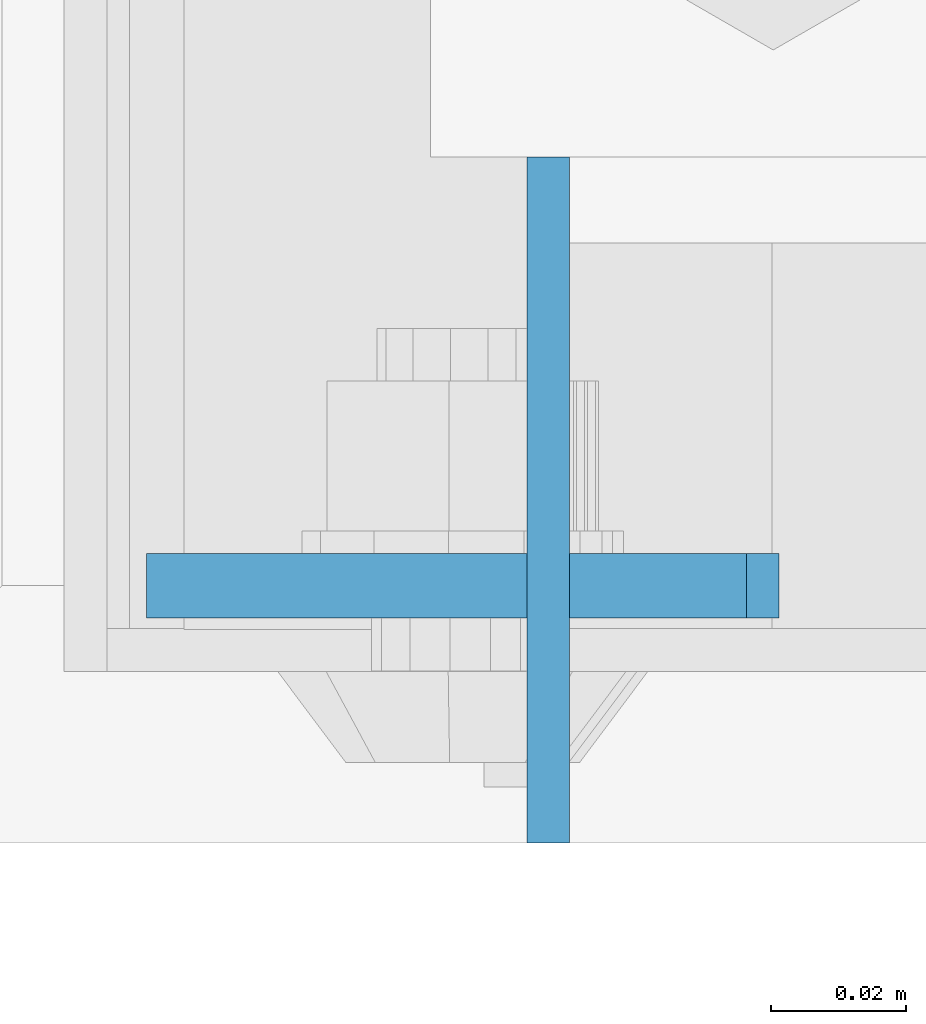
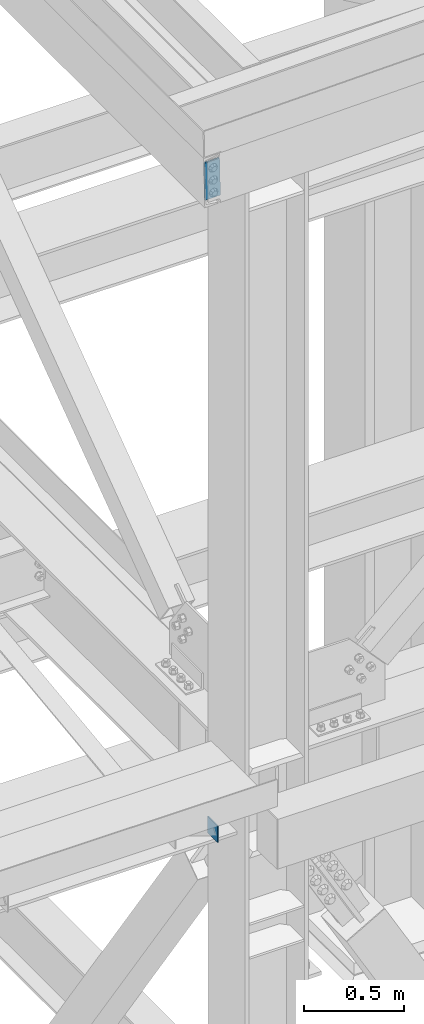
# One storey, part 3091 of 3843: 2 plates, 2 elements without a shape of their own.
"""IFC2X3 building model written with IfcOpenShell, lengths in millimetres."""

from ifc_helpers import new_model, si_unit, frame, origin_with_axes, place, context, subcontext, project, spatial, faceted_brep, material, type_object, element, aggregate, save


model = new_model("IFC2X3")

# Units and contexts
model_context = context("Model", 3, precision=1e-05, world=origin_with_axes())
body_context = subcontext(model_context, "Body", "Model", "MODEL_VIEW")
ifc_project = project(units=[si_unit("LENGTHUNIT", "METRE", prefix="MILLI"), si_unit("AREAUNIT", "SQUARE_METRE"), si_unit("VOLUMEUNIT", "CUBIC_METRE"), si_unit("MASSUNIT", "GRAM", prefix="KILO"), si_unit("TIMEUNIT", "SECOND"), si_unit("PLANEANGLEUNIT", "RADIAN"), si_unit("SOLIDANGLEUNIT", "STERADIAN"), si_unit("THERMODYNAMICTEMPERATUREUNIT", "DEGREE_CELSIUS"), si_unit("LUMINOUSINTENSITYUNIT", "LUMEN")], contexts=[model_context])

# Site, building, storey
site_placement = place(None, origin_with_axes())
site = spatial("IfcSite", under=ifc_project, at=site_placement, CompositionType="ELEMENT")
building_placement = place(site_placement, origin_with_axes())
building = spatial("IfcBuilding", under=site, at=building_placement, Name="Undefined", CompositionType="ELEMENT")
storey_placement = place(building_placement, origin_with_axes())
storey = spatial("IfcBuildingStorey", under=building, at=storey_placement, Name="Undefined", CompositionType="ELEMENT", Elevation=0.0)

# Assembly, plate
assembly_1_placement = place(storey_placement, origin_with_axes())
assembly_1 = element("IfcElementAssembly", 1, at=assembly_1_placement, inside=storey, Name="CHANNEL", AssemblyPlace="NOTDEFINED", PredefinedType="RIGID_FRAME")
ifc_material = material(Name="STEEL/A572-50")
plate_type_1 = type_object("IfcPlateType", PredefinedType="NOTDEFINED")
plate_1_placement = place(assembly_1_placement, frame((76411.9416190508, 14503.4, 46534.288407765), z_axis=(0.999776270257024, 0.0, 0.0211520550054619), x_axis=(0.0211520550054438, 0.0, -0.999776270257025)))
plate_1 = element("IfcPlate", 2, at=plate_1_placement, type_object=plate_type_1, material=ifc_material, Name="PLATE", context=body_context, shape_type="Brep", body=[
    faceted_brep([(0.0, -4.76249999999709, 0.0), (0.0, -4.76249999999709, 88.9000015258789), (0.0, 4.76249999999709, 88.9000015258789), (0.0, 4.76249999999709, 0.0), (228.600006102781, -4.7625000004191, 88.9000015257589), (228.600006102781, 4.76249999954598, 88.9000015257443), (228.600006103079, -4.7625000004482, 7.27595761418343e-12), (228.600006103079, 4.76249999954598, -7.27595761418343e-12)], [[[0, 1, 2, 3]], [[1, 4, 5, 2]], [[4, 6, 7, 5]], [[6, 0, 3, 7]], [[5, 7, 3, 2]], [[6, 4, 1, 0]]]),
])
aggregate(assembly_1, [plate_1])

assembly_2_placement = place(storey_placement, origin_with_axes())
assembly_2 = element("IfcElementAssembly", 3, at=assembly_2_placement, inside=storey, Name="BEAM", AssemblyPlace="NOTDEFINED", PredefinedType="RIGID_FRAME")
plate_type_2 = type_object("IfcPlateType", PredefinedType="NOTDEFINED")
plate_2_placement = place(assembly_2_placement, frame((76471.4625, 14566.8999999151, 42468.7999999095), z_axis=(0.0, 0.0, -1.0), x_axis=(0.0, -1.0, 0.0)))
plate_2 = element("IfcPlate", 4, at=plate_2_placement, type_object=plate_type_2, material=ifc_material, Name="PLATE", context=body_context, shape_type="Brep", body=[
    faceted_brep([(0.0, -3.17499999999927, 0.0), (0.0, -3.17499999999927, 101.600000000006), (0.0, 3.17499999999927, 101.600000000006), (0.0, 3.17499999999927, 0.0), (101.6, -3.17500000000291, 101.599999999999), (101.6, 3.17500000000291, 101.599999999999), (101.600000000035, -3.17500000000291, -7.27595761418343e-12), (101.600000000035, 3.17500000000291, -7.27595761418343e-12)], [[[0, 1, 2, 3]], [[1, 4, 5, 2]], [[4, 6, 7, 5]], [[6, 0, 3, 7]], [[5, 7, 3, 2]], [[6, 4, 1, 0]]]),
])
aggregate(assembly_2, [plate_2])

save(model, "model.ifc")
